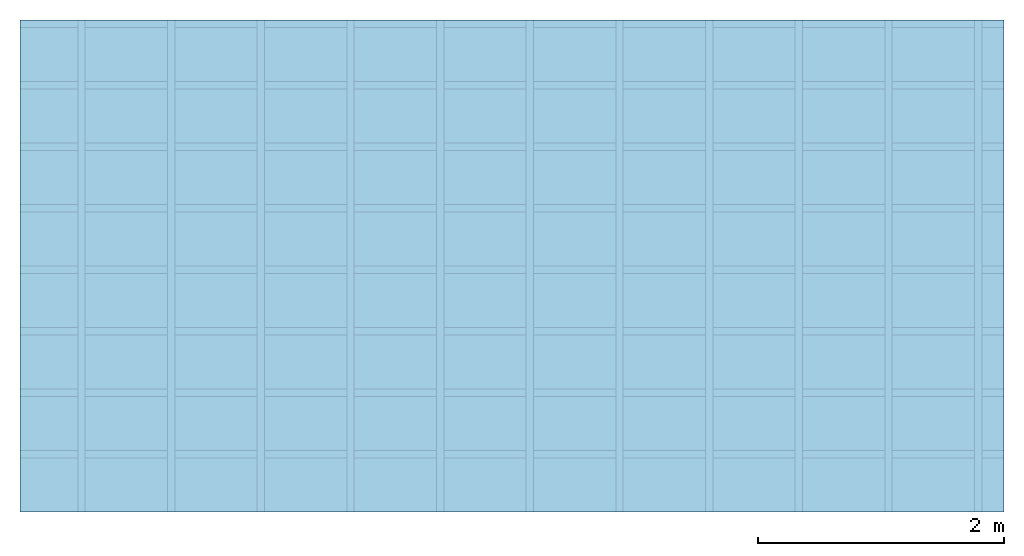
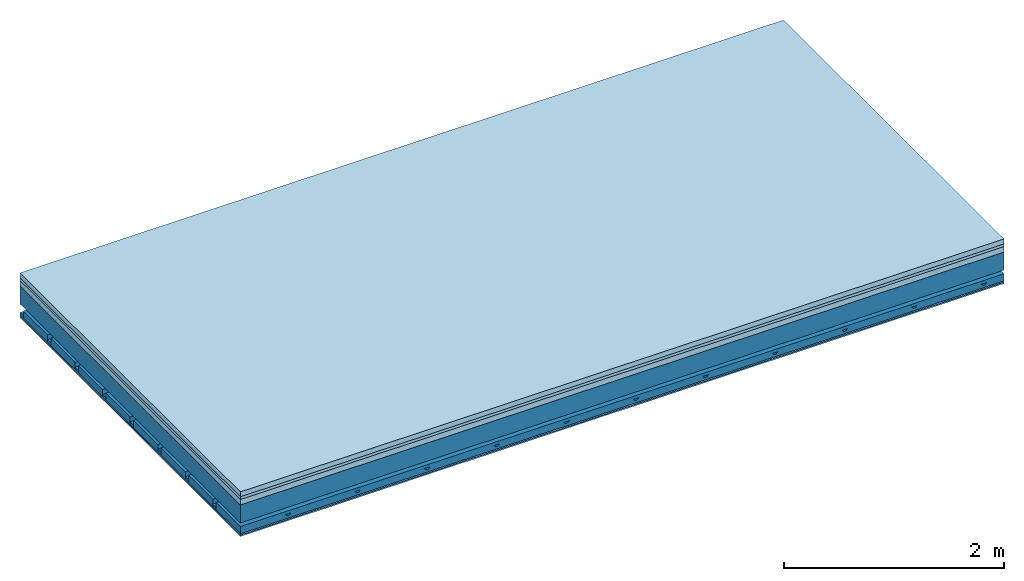
# One storey: 5 plates, 4 members, 1 element without a shape of its own.
"""IFC4 building model written with IfcOpenShell, lengths in metres."""

from ifc_helpers import new_model, si_unit, derived_unit, direction, frame, frame_2d, origin, origin_with_axes, place, context, project, spatial, polyline, rectangle, outline, extrude, material, layer, layer_set, type_object, element, aggregate, save


model = new_model("IFC4")

# Units and contexts
plan_context = context("Plan", 3, precision=1e-05, world=origin(), true_north=direction((0.0, 1.0)))
model_context = context("Model", 3, precision=1e-05, world=origin(), true_north=direction((0.0, 1.0)))
ifc_project = project(units=[si_unit("LENGTHUNIT", "METRE"), derived_unit("SOUNDPRESSUREUNIT", [(si_unit("PRESSUREUNIT", "PASCAL", prefix="MICRO"), 0)]), si_unit("ENERGYUNIT", "JOULE", prefix="MEGA"), si_unit("MASSUNIT", "GRAM", prefix="KILO"), derived_unit("THERMALTRANSMITTANCEUNIT", [(si_unit("POWERUNIT", "WATT"), 1), (si_unit("AREAUNIT", "SQUARE_METRE"), -1), (si_unit("THERMODYNAMICTEMPERATUREUNIT", "KELVIN"), -1)]), derived_unit("AREADENSITYUNIT", [(si_unit("MASSUNIT", "GRAM", prefix="KILO"), 1), (si_unit("AREAUNIT", "SQUARE_METRE"), -1)]), derived_unit("USERDEFINED", [(si_unit("ENERGYUNIT", "JOULE", prefix="MEGA"), 1), (si_unit("AREAUNIT", "SQUARE_METRE"), -1)])], contexts=[plan_context, model_context])

# Site, building, storey
site = spatial("IfcSite", under=ifc_project)
building_placement = place(None, origin())
building = spatial("IfcBuilding", under=site, at=building_placement)
storey_placement = place(building_placement, origin())
storey = spatial("IfcBuildingStorey", under=building, at=storey_placement)

# Slab, members, plates
ifc_material_1 = material(Category="04.005")
ifc_layer_1 = layer(ifc_material_1, 0.055, Name="On-material")
ifc_material_2 = material()
ifc_layer_2 = layer(ifc_material_2, 0.03, Name="Impact sound insulation")
ifc_material_3 = material(Category="03.011")
ifc_layer_3 = layer(ifc_material_3, 0.06, Name="on Supporting structure")
ifc_layer_4 = layer(None, 0.2, Name="Supporting structure")
ifc_material_4 = material(Name="no composite action")
ifc_layer_5 = layer(ifc_material_4, 0.0, Name="Bond")
ifc_layer_6 = layer(None, 0.093, Name="Coupling")
ifc_layer_7 = layer(None, 0.027, Name="Battens / profiles")
ifc_material_5 = material(Category="03.007")
ifc_layer_8 = layer(ifc_material_5, 0.015, Name="Ceiling covering 1st layer")
ifc_layer_9 = layer(ifc_material_5, 0.015, Name="Ceiling covering layer 2")
ifc_material_6 = material(Name="Glued joints")
ifc_layer_10 = layer(ifc_material_6, 0.0, Name="Surface / treatment")
ifc_layer_set = layer_set([ifc_layer_1, ifc_layer_2, ifc_layer_3, ifc_layer_4, ifc_layer_5, ifc_layer_6, ifc_layer_7, ifc_layer_8, ifc_layer_9, ifc_layer_10])
slab_type = type_object("IfcSlabType", Name="A1160", PredefinedType="NOTDEFINED", material=ifc_layer_set)
slab_placement = place(None, frame((0.0, 0.0, 0.0), z_axis=(0.0, 0.0, -1.0), x_axis=(1.0, 0.0, 0.0)))
slab = element("IfcSlab", 1, at=slab_placement, inside=storey, type_object=slab_type, material=ifc_layer_set, Name="Slab #1")
ifc_material_7 = material()
member_1_placement = place(slab_placement, origin())
member_1 = element("IfcMember", 2, at=member_1_placement, material=ifc_material_7, Name="Supporting structure", context=plan_context, shape_type="SweptSolid", body=[
    extrude(rectangle(XDim=1.0, YDim=0.2, at=frame_2d((0.5, 0.1), x_axis=(1.0, 0.0))), frame((0.0, 4.0, 0.145), z_axis=(0.0, -1.0, 0.0), x_axis=(1.0, 0.0, 0.0)), (0.0, 0.0, 1.0), 4.0),
    extrude(rectangle(XDim=1.0, YDim=0.2, at=frame_2d((0.5, 0.1), x_axis=(1.0, 0.0))), frame((1.0, 4.0, 0.145), z_axis=(0.0, -1.0, 0.0), x_axis=(1.0, 0.0, 0.0)), (0.0, 0.0, 1.0), 4.0),
    extrude(rectangle(XDim=1.0, YDim=0.2, at=frame_2d((0.5, 0.1), x_axis=(1.0, 0.0))), frame((2.0, 4.0, 0.145), z_axis=(0.0, -1.0, 0.0), x_axis=(1.0, 0.0, 0.0)), (0.0, 0.0, 1.0), 4.0),
    extrude(rectangle(XDim=1.0, YDim=0.2, at=frame_2d((0.5, 0.1), x_axis=(1.0, 0.0))), frame((3.0, 4.0, 0.145), z_axis=(0.0, -1.0, 0.0), x_axis=(1.0, 0.0, 0.0)), (0.0, 0.0, 1.0), 4.0),
    extrude(rectangle(XDim=1.0, YDim=0.2, at=frame_2d((0.5, 0.1), x_axis=(1.0, 0.0))), frame((4.0, 4.0, 0.145), z_axis=(0.0, -1.0, 0.0), x_axis=(1.0, 0.0, 0.0)), (0.0, 0.0, 1.0), 4.0),
    extrude(rectangle(XDim=1.0, YDim=0.2, at=frame_2d((0.5, 0.1), x_axis=(1.0, 0.0))), frame((5.0, 4.0, 0.145), z_axis=(0.0, -1.0, 0.0), x_axis=(1.0, 0.0, 0.0)), (0.0, 0.0, 1.0), 4.0),
    extrude(rectangle(XDim=1.0, YDim=0.2, at=frame_2d((0.5, 0.1), x_axis=(1.0, 0.0))), frame((6.0, 4.0, 0.145), z_axis=(0.0, -1.0, 0.0), x_axis=(1.0, 0.0, 0.0)), (0.0, 0.0, 1.0), 4.0),
    extrude(rectangle(XDim=1.0, YDim=0.2, at=frame_2d((0.5, 0.1), x_axis=(1.0, 0.0))), frame((7.0, 4.0, 0.145), z_axis=(0.0, -1.0, 0.0), x_axis=(1.0, 0.0, 0.0)), (0.0, 0.0, 1.0), 4.0),
])
ifc_material_8 = material()
member_2_placement = place(slab_placement, origin())
member_2 = element("IfcMember", 3, at=member_2_placement, material=ifc_material_8, Name="Coupling", context=plan_context, shape_type="SweptSolid", body=[
    extrude(outline(polyline([(0.0, 0.0), (0.06, 0.0), (0.04, 0.02), (0.02, 0.02), (0.0, 0.0)])), frame((0.47, 4.0, 0.418), z_axis=(0.0, -1.0, 0.0), x_axis=(1.0, 0.0, 0.0)), (0.0, 0.0, 1.0), 4.0),
    extrude(outline(polyline([(0.0, 0.0), (0.06, 0.0), (0.04, 0.02), (0.02, 0.02), (0.0, 0.0)])), frame((1.199, 4.0, 0.418), z_axis=(0.0, -1.0, 0.0), x_axis=(1.0, 0.0, 0.0)), (0.0, 0.0, 1.0), 4.0),
    extrude(outline(polyline([(0.0, 0.0), (0.06, 0.0), (0.04, 0.02), (0.02, 0.02), (0.0, 0.0)])), frame((1.928, 4.0, 0.418), z_axis=(0.0, -1.0, 0.0), x_axis=(1.0, 0.0, 0.0)), (0.0, 0.0, 1.0), 4.0),
    extrude(outline(polyline([(0.0, 0.0), (0.06, 0.0), (0.04, 0.02), (0.02, 0.02), (0.0, 0.0)])), frame((2.657, 4.0, 0.418), z_axis=(0.0, -1.0, 0.0), x_axis=(1.0, 0.0, 0.0)), (0.0, 0.0, 1.0), 4.0),
    extrude(outline(polyline([(0.0, 0.0), (0.06, 0.0), (0.04, 0.02), (0.02, 0.02), (0.0, 0.0)])), frame((3.386, 4.0, 0.418), z_axis=(0.0, -1.0, 0.0), x_axis=(1.0, 0.0, 0.0)), (0.0, 0.0, 1.0), 4.0),
    extrude(outline(polyline([(0.0, 0.0), (0.06, 0.0), (0.04, 0.02), (0.02, 0.02), (0.0, 0.0)])), frame((4.115, 4.0, 0.418), z_axis=(0.0, -1.0, 0.0), x_axis=(1.0, 0.0, 0.0)), (0.0, 0.0, 1.0), 4.0),
    extrude(outline(polyline([(0.0, 0.0), (0.06, 0.0), (0.04, 0.02), (0.02, 0.02), (0.0, 0.0)])), frame((4.844, 4.0, 0.418), z_axis=(0.0, -1.0, 0.0), x_axis=(1.0, 0.0, 0.0)), (0.0, 0.0, 1.0), 4.0),
    extrude(outline(polyline([(0.0, 0.0), (0.06, 0.0), (0.04, 0.02), (0.02, 0.02), (0.0, 0.0)])), frame((5.573, 4.0, 0.418), z_axis=(0.0, -1.0, 0.0), x_axis=(1.0, 0.0, 0.0)), (0.0, 0.0, 1.0), 4.0),
    extrude(outline(polyline([(0.0, 0.0), (0.06, 0.0), (0.04, 0.02), (0.02, 0.02), (0.0, 0.0)])), frame((6.302, 4.0, 0.418), z_axis=(0.0, -1.0, 0.0), x_axis=(1.0, 0.0, 0.0)), (0.0, 0.0, 1.0), 4.0),
    extrude(outline(polyline([(0.0, 0.0), (0.06, 0.0), (0.04, 0.02), (0.02, 0.02), (0.0, 0.0)])), frame((7.031, 4.0, 0.418), z_axis=(0.0, -1.0, 0.0), x_axis=(1.0, 0.0, 0.0)), (0.0, 0.0, 1.0), 4.0),
    extrude(outline(polyline([(0.0, 0.0), (0.06, 0.0), (0.04, 0.02), (0.02, 0.02), (0.0, 0.0)])), frame((7.76, 4.0, 0.418), z_axis=(0.0, -1.0, 0.0), x_axis=(1.0, 0.0, 0.0)), (0.0, 0.0, 1.0), 4.0),
])
ifc_material_9 = material()
member_3_placement = place(slab_placement, origin())
member_3 = element("IfcMember", 4, at=member_3_placement, material=ifc_material_9, Name="Battens / profiles", context=plan_context, shape_type="SweptSolid", body=[
    extrude(rectangle(XDim=0.06, YDim=0.027, at=frame_2d((0.03, 0.0135), x_axis=(1.0, 0.0))), frame((0.0, 0.0, 0.438), z_axis=(1.0, 0.0, 0.0), x_axis=(0.0, 1.0, 0.0)), (0.0, 0.0, 1.0), 8.0),
    extrude(rectangle(XDim=0.06, YDim=0.027, at=frame_2d((0.03, 0.0135), x_axis=(1.0, 0.0))), frame((0.0, 0.5, 0.438), z_axis=(1.0, 0.0, 0.0), x_axis=(0.0, 1.0, 0.0)), (0.0, 0.0, 1.0), 8.0),
    extrude(rectangle(XDim=0.06, YDim=0.027, at=frame_2d((0.03, 0.0135), x_axis=(1.0, 0.0))), frame((0.0, 1.0, 0.438), z_axis=(1.0, 0.0, 0.0), x_axis=(0.0, 1.0, 0.0)), (0.0, 0.0, 1.0), 8.0),
    extrude(rectangle(XDim=0.06, YDim=0.027, at=frame_2d((0.03, 0.0135), x_axis=(1.0, 0.0))), frame((0.0, 1.5, 0.438), z_axis=(1.0, 0.0, 0.0), x_axis=(0.0, 1.0, 0.0)), (0.0, 0.0, 1.0), 8.0),
    extrude(rectangle(XDim=0.06, YDim=0.027, at=frame_2d((0.03, 0.0135), x_axis=(1.0, 0.0))), frame((0.0, 2.0, 0.438), z_axis=(1.0, 0.0, 0.0), x_axis=(0.0, 1.0, 0.0)), (0.0, 0.0, 1.0), 8.0),
    extrude(rectangle(XDim=0.06, YDim=0.027, at=frame_2d((0.03, 0.0135), x_axis=(1.0, 0.0))), frame((0.0, 2.5, 0.438), z_axis=(1.0, 0.0, 0.0), x_axis=(0.0, 1.0, 0.0)), (0.0, 0.0, 1.0), 8.0),
    extrude(rectangle(XDim=0.06, YDim=0.027, at=frame_2d((0.03, 0.0135), x_axis=(1.0, 0.0))), frame((0.0, 3.0, 0.438), z_axis=(1.0, 0.0, 0.0), x_axis=(0.0, 1.0, 0.0)), (0.0, 0.0, 1.0), 8.0),
    extrude(rectangle(XDim=0.06, YDim=0.027, at=frame_2d((0.03, 0.0135), x_axis=(1.0, 0.0))), frame((0.0, 3.5, 0.438), z_axis=(1.0, 0.0, 0.0), x_axis=(0.0, 1.0, 0.0)), (0.0, 0.0, 1.0), 8.0),
])
ifc_material_10 = material()
member_4_placement = place(slab_placement, origin())
member_4 = element("IfcMember", 5, at=member_4_placement, material=ifc_material_10, Name="Cavity", context=plan_context, shape_type="SweptSolid", body=[
    extrude(rectangle(XDim=0.44, YDim=0.08, at=frame_2d((0.22, 0.04), x_axis=(1.0, 0.0))), frame((0.0, 0.06, 0.385), z_axis=(1.0, 0.0, 0.0), x_axis=(0.0, 1.0, 0.0)), (0.0, 0.0, 1.0), 8.0),
    extrude(rectangle(XDim=0.44, YDim=0.08, at=frame_2d((0.22, 0.04), x_axis=(1.0, 0.0))), frame((0.0, 0.56, 0.385), z_axis=(1.0, 0.0, 0.0), x_axis=(0.0, 1.0, 0.0)), (0.0, 0.0, 1.0), 8.0),
    extrude(rectangle(XDim=0.44, YDim=0.08, at=frame_2d((0.22, 0.04), x_axis=(1.0, 0.0))), frame((0.0, 1.06, 0.385), z_axis=(1.0, 0.0, 0.0), x_axis=(0.0, 1.0, 0.0)), (0.0, 0.0, 1.0), 8.0),
    extrude(rectangle(XDim=0.44, YDim=0.08, at=frame_2d((0.22, 0.04), x_axis=(1.0, 0.0))), frame((0.0, 1.56, 0.385), z_axis=(1.0, 0.0, 0.0), x_axis=(0.0, 1.0, 0.0)), (0.0, 0.0, 1.0), 8.0),
    extrude(rectangle(XDim=0.44, YDim=0.08, at=frame_2d((0.22, 0.04), x_axis=(1.0, 0.0))), frame((0.0, 2.06, 0.385), z_axis=(1.0, 0.0, 0.0), x_axis=(0.0, 1.0, 0.0)), (0.0, 0.0, 1.0), 8.0),
    extrude(rectangle(XDim=0.44, YDim=0.08, at=frame_2d((0.22, 0.04), x_axis=(1.0, 0.0))), frame((0.0, 2.56, 0.385), z_axis=(1.0, 0.0, 0.0), x_axis=(0.0, 1.0, 0.0)), (0.0, 0.0, 1.0), 8.0),
    extrude(rectangle(XDim=0.44, YDim=0.08, at=frame_2d((0.22, 0.04), x_axis=(1.0, 0.0))), frame((0.0, 3.06, 0.385), z_axis=(1.0, 0.0, 0.0), x_axis=(0.0, 1.0, 0.0)), (0.0, 0.0, 1.0), 8.0),
    extrude(rectangle(XDim=0.44, YDim=0.08, at=frame_2d((0.22, 0.04), x_axis=(1.0, 0.0))), frame((0.0, 3.56, 0.385), z_axis=(1.0, 0.0, 0.0), x_axis=(0.0, 1.0, 0.0)), (0.0, 0.0, 1.0), 8.0),
])
plate_1_placement = place(slab_placement, origin())
plate_1 = element("IfcPlate", 6, at=plate_1_placement, material=ifc_material_1, Name="On-material", context=plan_context, shape_type="SweptSolid", body=[
    extrude(rectangle(XDim=8.0, YDim=4.0, at=frame_2d((4.0, 2.0), x_axis=(1.0, 0.0))), origin_with_axes(), (0.0, 0.0, 1.0), 0.055),
])
plate_2_placement = place(slab_placement, origin())
plate_2 = element("IfcPlate", 7, at=plate_2_placement, material=ifc_material_2, Name="Impact sound insulation", context=plan_context, shape_type="SweptSolid", body=[
    extrude(rectangle(XDim=8.0, YDim=4.0, at=frame_2d((4.0, 2.0), x_axis=(1.0, 0.0))), frame((0.0, 0.0, 0.055), z_axis=(0.0, 0.0, 1.0), x_axis=(1.0, 0.0, 0.0)), (0.0, 0.0, 1.0), 0.03),
])
plate_3_placement = place(slab_placement, origin())
plate_3 = element("IfcPlate", 8, at=plate_3_placement, material=ifc_material_3, Name="on Supporting structure", context=plan_context, shape_type="SweptSolid", body=[
    extrude(rectangle(XDim=8.0, YDim=4.0, at=frame_2d((4.0, 2.0), x_axis=(1.0, 0.0))), frame((0.0, 0.0, 0.085), z_axis=(0.0, 0.0, 1.0), x_axis=(1.0, 0.0, 0.0)), (0.0, 0.0, 1.0), 0.06),
])
plate_4_placement = place(slab_placement, origin())
plate_4 = element("IfcPlate", 9, at=plate_4_placement, material=ifc_material_5, Name="Ceiling covering 1st layer", context=plan_context, shape_type="SweptSolid", body=[
    extrude(rectangle(XDim=8.0, YDim=4.0, at=frame_2d((4.0, 2.0), x_axis=(1.0, 0.0))), frame((0.0, 0.0, 0.465), z_axis=(0.0, 0.0, 1.0), x_axis=(1.0, 0.0, 0.0)), (0.0, 0.0, 1.0), 0.015),
])
plate_5_placement = place(slab_placement, origin())
plate_5 = element("IfcPlate", 10, at=plate_5_placement, material=ifc_material_5, Name="Ceiling covering layer 2", context=plan_context, shape_type="SweptSolid", body=[
    extrude(rectangle(XDim=8.0, YDim=4.0, at=frame_2d((4.0, 2.0), x_axis=(1.0, 0.0))), frame((0.0, 0.0, 0.48), z_axis=(0.0, 0.0, 1.0), x_axis=(1.0, 0.0, 0.0)), (0.0, 0.0, 1.0), 0.015),
])
aggregate(slab, [plate_1, plate_2, plate_3, member_1, member_2, member_3, member_4, plate_4, plate_5])

save(model, "model.ifc")
